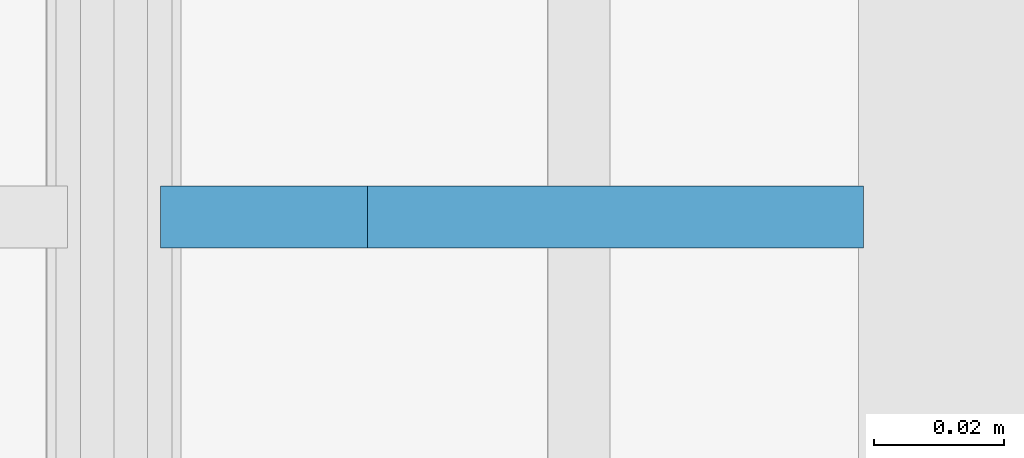
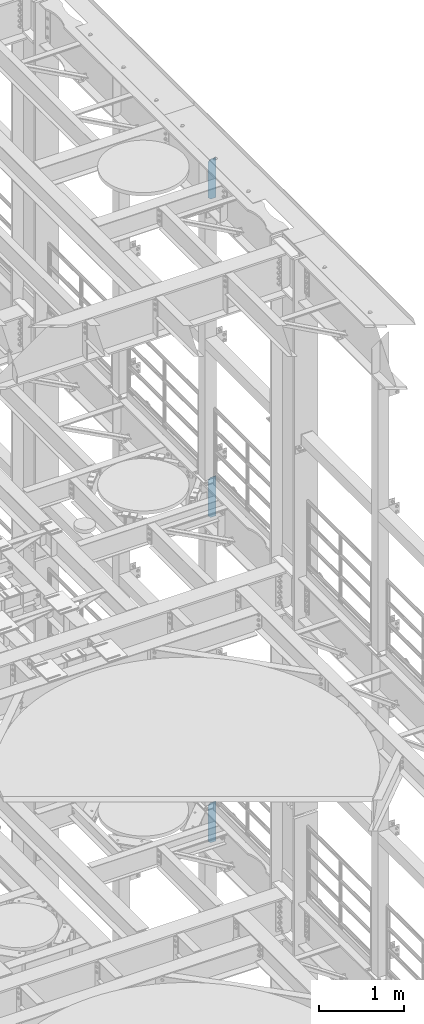
# One storey, part 1679 of 1876: 3 plates, 3 elements without a shape of their own.
"""IFC2X3 building model written with IfcOpenShell, lengths in millimetres."""

from ifc_helpers import new_model, si_unit, frame, origin_with_axes, place, context, subcontext, project, spatial, faceted_brep, material, type_object, element, aggregate, save


model = new_model("IFC2X3")

# Units and contexts
model_context = context("Model", 3, precision=1e-05, world=origin_with_axes())
body_context = subcontext(model_context, "Body", "Model", "MODEL_VIEW")
ifc_project = project(units=[si_unit("LENGTHUNIT", "METRE", prefix="MILLI"), si_unit("AREAUNIT", "SQUARE_METRE"), si_unit("VOLUMEUNIT", "CUBIC_METRE"), si_unit("MASSUNIT", "GRAM", prefix="KILO"), si_unit("TIMEUNIT", "SECOND"), si_unit("PLANEANGLEUNIT", "RADIAN"), si_unit("SOLIDANGLEUNIT", "STERADIAN"), si_unit("THERMODYNAMICTEMPERATUREUNIT", "DEGREE_CELSIUS"), si_unit("LUMINOUSINTENSITYUNIT", "LUMEN")], contexts=[model_context])

# Site, building, storey
site_placement = place(None, origin_with_axes())
site = spatial("IfcSite", under=ifc_project, at=site_placement, CompositionType="ELEMENT")
building_placement = place(site_placement, origin_with_axes())
building = spatial("IfcBuilding", under=site, at=building_placement, Name="Undefined", CompositionType="ELEMENT")
storey_placement = place(building_placement, origin_with_axes())
storey = spatial("IfcBuildingStorey", under=building, at=storey_placement, Name="Undefined", CompositionType="ELEMENT", Elevation=0.0)

# Assembly, plate
assembly_1_placement = place(storey_placement, origin_with_axes())
assembly_1 = element("IfcElementAssembly", 1, at=assembly_1_placement, inside=storey, Name="BEAM", AssemblyPlace="NOTDEFINED", PredefinedType="RIGID_FRAME")
ifc_material = material(Name="STEEL/A36")
plate_type = type_object("IfcPlateType", PredefinedType="NOTDEFINED")
plate_1_placement = place(assembly_1_placement, frame((7735.09375, 3556.0, 21958.3), z_axis=(0.0, 0.0, 1.0), x_axis=(-1.0, 0.0, 0.0)))
plate_1 = element("IfcPlate", 2, at=plate_1_placement, type_object=plate_type, material=ifc_material, Name="PLATE", context=body_context, shape_type="Brep", body=[
    faceted_brep([(0.0, -4.76249999999982, 0.0), (0.0, -4.76249999999982, 571.5), (0.0, 4.76249999999982, 571.5), (0.0, 4.76249999999982, 0.0), (76.1999969482422, -4.76249999999982, 571.5), (76.1999969482422, 4.76249999999982, 571.5), (107.949996948242, -4.76249999999982, 539.75), (107.949996948242, 4.76249999999982, 539.75), (107.949996948242, -4.76249999999982, 31.75), (107.949996948242, 4.76249999999982, 31.75), (76.1999969482422, -4.76250000000073, 0.0), (76.1999969482422, 4.76250000000073, 0.0)], [[[0, 1, 2, 3]], [[1, 4, 5, 2]], [[4, 6, 7, 5]], [[6, 8, 9, 7]], [[8, 10, 11, 9]], [[10, 0, 3, 11]], [[5, 7, 9, 11, 3, 2]], [[10, 8, 6, 4, 1, 0]]]),
])
aggregate(assembly_1, [plate_1])

assembly_2_placement = place(storey_placement, origin_with_axes())
assembly_2 = element("IfcElementAssembly", 3, at=assembly_2_placement, inside=storey, Name="BEAM", AssemblyPlace="NOTDEFINED", PredefinedType="RIGID_FRAME")
plate_2_placement = place(assembly_2_placement, frame((7735.09375, 3556.0, 17386.3), z_axis=(0.0, 0.0, 1.0), x_axis=(-1.0, 0.0, 0.0)))
plate_2 = element("IfcPlate", 4, at=plate_2_placement, type_object=plate_type, material=ifc_material, Name="PLATE", context=body_context, shape_type="Brep", body=[
    faceted_brep([(0.0, -4.76249999999982, 0.0), (0.0, -4.76249999999982, 571.5), (0.0, 4.76249999999982, 571.5), (0.0, 4.76249999999982, 0.0), (76.1999969482422, -4.76249999999982, 571.5), (76.1999969482422, 4.76249999999982, 571.5), (107.949996948242, -4.76249999999982, 539.75), (107.949996948242, 4.76249999999982, 539.75), (107.949996948242, -4.76249999999982, 31.75), (107.949996948242, 4.76249999999982, 31.75), (76.1999969482422, -4.76250000000073, 0.0), (76.1999969482422, 4.76250000000073, 0.0)], [[[0, 1, 2, 3]], [[1, 4, 5, 2]], [[4, 6, 7, 5]], [[6, 8, 9, 7]], [[8, 10, 11, 9]], [[10, 0, 3, 11]], [[5, 7, 9, 11, 3, 2]], [[10, 8, 6, 4, 1, 0]]]),
])
aggregate(assembly_2, [plate_2])

assembly_3_placement = place(storey_placement, origin_with_axes())
assembly_3 = element("IfcElementAssembly", 5, at=assembly_3_placement, inside=storey, Name="BEAM", AssemblyPlace="NOTDEFINED", PredefinedType="RIGID_FRAME")
plate_3_placement = place(assembly_3_placement, frame((7735.09375, 3556.0, 12712.7), z_axis=(0.0, 0.0, 1.0), x_axis=(-1.0, 0.0, 0.0)))
plate_3 = element("IfcPlate", 6, at=plate_3_placement, type_object=plate_type, material=ifc_material, Name="PLATE", context=body_context, shape_type="Brep", body=[
    faceted_brep([(0.0, -4.76249999999982, 0.0), (0.0, -4.76249999999982, 571.5), (0.0, 4.76249999999982, 571.5), (0.0, 4.76249999999982, 0.0), (76.1999969482422, -4.76249999999982, 571.5), (76.1999969482422, 4.76249999999982, 571.5), (107.949996948242, -4.76249999999982, 539.75), (107.949996948242, 4.76249999999982, 539.75), (107.949996948242, -4.76249999999982, 31.75), (107.949996948242, 4.76249999999982, 31.75), (76.1999969482422, -4.76250000000073, 0.0), (76.1999969482422, 4.76250000000073, 0.0)], [[[0, 1, 2, 3]], [[1, 4, 5, 2]], [[4, 6, 7, 5]], [[6, 8, 9, 7]], [[8, 10, 11, 9]], [[10, 0, 3, 11]], [[5, 7, 9, 11, 3, 2]], [[10, 8, 6, 4, 1, 0]]]),
])
aggregate(assembly_3, [plate_3])

save(model, "model.ifc")
